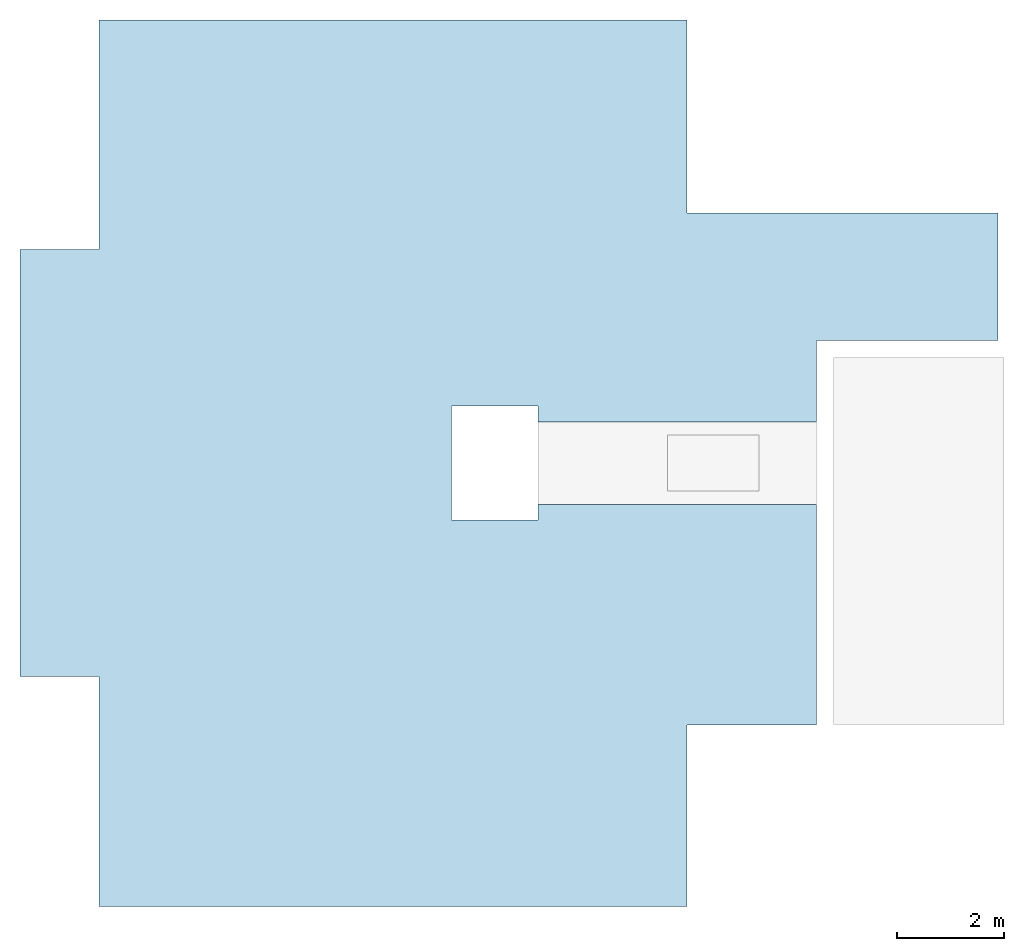
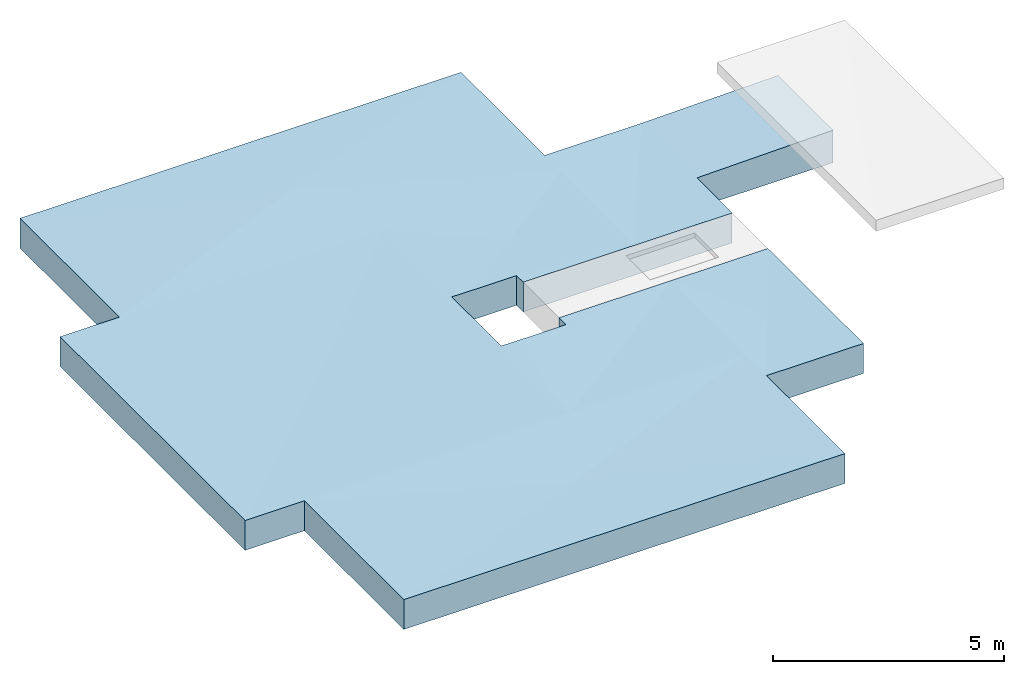
# One storey, part 2 of 2: 1 slab.
"""IFC2X3 building model written with IfcOpenShell, lengths in millimetres."""

from ifc_helpers import new_model, entity, si_unit, converted_unit, derived_unit, direction, frame, origin, place, context, subcontext, project, spatial, faceted_brep, material, material_list, type_object, element, save


model = new_model("IFC2X3")

# Units and contexts
model_context = context("Model", 3, precision=0.01, world=origin(), true_north=direction((6.12303176911189e-17, 1.0)))
body_context = subcontext(model_context, "Body", "Model", "MODEL_VIEW")
ifc_project = project(units=[si_unit("LENGTHUNIT", "METRE", prefix="MILLI"), si_unit("AREAUNIT", "SQUARE_METRE"), si_unit("VOLUMEUNIT", "CUBIC_METRE"), converted_unit("PLANEANGLEUNIT", "DEGREE", entity("IfcRatioMeasure", 0.0174532925199433), si_unit("PLANEANGLEUNIT", "RADIAN"), dimensions=[0, 0, 0, 0, 0, 0, 0]), si_unit("MASSUNIT", "GRAM", prefix="KILO"), derived_unit("MASSDENSITYUNIT", [(si_unit("MASSUNIT", "GRAM", prefix="KILO"), 1), (si_unit("LENGTHUNIT", "METRE"), -3)]), si_unit("TIMEUNIT", "SECOND"), si_unit("FREQUENCYUNIT", "HERTZ"), si_unit("THERMODYNAMICTEMPERATUREUNIT", "DEGREE_CELSIUS"), derived_unit("THERMALTRANSMITTANCEUNIT", [(si_unit("MASSUNIT", "GRAM", prefix="KILO"), 1), (si_unit("THERMODYNAMICTEMPERATUREUNIT", "KELVIN"), -1), (si_unit("TIMEUNIT", "SECOND"), -3)]), derived_unit("VOLUMETRICFLOWRATEUNIT", [(si_unit("LENGTHUNIT", "METRE"), 3), (si_unit("TIMEUNIT", "SECOND"), -1)]), si_unit("ELECTRICCURRENTUNIT", "AMPERE"), si_unit("ELECTRICVOLTAGEUNIT", "VOLT"), si_unit("POWERUNIT", "WATT"), si_unit("FORCEUNIT", "NEWTON", prefix="KILO"), si_unit("ILLUMINANCEUNIT", "LUX"), si_unit("LUMINOUSFLUXUNIT", "LUMEN"), si_unit("LUMINOUSINTENSITYUNIT", "CANDELA"), derived_unit("USERDEFINED", [(si_unit("MASSUNIT", "GRAM", prefix="KILO"), -1), (si_unit("LENGTHUNIT", "METRE"), -2), (si_unit("TIMEUNIT", "SECOND"), 3), (si_unit("LUMINOUSFLUXUNIT", "LUMEN"), 1)]), derived_unit("LINEARVELOCITYUNIT", [(si_unit("LENGTHUNIT", "METRE"), 1), (si_unit("TIMEUNIT", "SECOND"), -1)]), si_unit("PRESSUREUNIT", "PASCAL"), derived_unit("USERDEFINED", [(si_unit("LENGTHUNIT", "METRE"), -2), (si_unit("MASSUNIT", "GRAM", prefix="KILO"), 1), (si_unit("TIMEUNIT", "SECOND"), -2)])], contexts=[model_context])

# Site, building, storey
site_placement = place(None, origin())
site = spatial("IfcSite", under=ifc_project, at=site_placement, CompositionType="ELEMENT")
building_placement = place(site_placement, origin())
building = spatial("IfcBuilding", under=site, at=building_placement, CompositionType="ELEMENT")
storey_placement = place(building_placement, frame((0.0, 0.0, 16000.0)))
storey = spatial("IfcBuildingStorey", under=building, at=storey_placement, Name="04 Roof", CompositionType="ELEMENT", Elevation=16000.0)

# Slab
ifc_material_1 = material()
ifc_material_2 = material(Name="01")
ifc_material_3 = material(Name="04_XPS PLUS 30 SF")
ifc_material_4 = material(Name="06_ APP")
ifc_material_5 = material(Name="02_Beton, C40/55")
ifc_material_list = material_list([ifc_material_1, ifc_material_2, ifc_material_3, ifc_material_4, ifc_material_5])
slab_type = type_object("IfcSlabType", Name="Floor", PredefinedType="FLOOR")
slab_placement = place(storey_placement, origin())
element("IfcSlab", 1, at=slab_placement, inside=storey, type_object=slab_type, material=ifc_material_list, Name="Floor", ObjectType="Floor", PredefinedType="FLOOR", context=body_context, shape_type="Brep", body=[
    faceted_brep([(28513.4900708518, -64135.8241905964, -140.0), (28813.4900708518, -64135.8241905964, -140.0), (28943.4900708518, -64135.8241905964, -140.0), (30943.4900708518, -64135.8241905964, -140.0), (34353.4900708518, -64135.8241905964, -140.0), (34353.4900708518, -64275.8241905964, -140.0), (34353.4900708518, -66525.8241905964, -140.0), (30943.4900708518, -66525.8241905964, -140.0), (30943.4900708518, -68056.2395851399, -140.0), (25713.4900708518, -68056.2395851399, -140.0), (25713.4900708518, -67761.2395851399, -140.0), (24093.4900708518, -67761.2395851399, -140.0), (24093.4900708518, -68071.2395851399, -140.0), (24093.4900708518, -69591.2395851399, -140.0), (24093.4900708518, -69901.2395851399, -140.0), (25713.4900708518, -69901.2395851399, -140.0), (25713.4900708518, -69606.2395851399, -140.0), (30943.4900708518, -69606.2395851399, -140.0), (30943.4900708518, -73750.8241905963, -140.0), (28943.4900708518, -73750.8241905963, -140.0), (28513.4900708518, -73750.8241905963, -140.0), (28513.4900708518, -75951.2395851399, -140.0), (28513.4900708518, -77011.2395851399, -140.0), (28513.4900708518, -77151.2395851399, -140.0), (17613.4900708518, -77151.2395851399, -140.0), (17473.4900708518, -77151.2395851399, -140.0), (17473.4900708518, -73271.2395851399, -140.0), (17473.4900708518, -72841.2395851399, -140.0), (16128.4900708518, -72841.2395851399, -140.0), (15988.4900708518, -72841.2395851399, -140.0), (15988.4900708518, -64961.2395851399, -140.0), (15988.4900708518, -64821.2395851399, -140.0), (17043.4900708518, -64821.2395851399, -140.0), (17173.4900708518, -64821.2395851399, -140.0), (17473.4900708518, -64821.2395851399, -140.0), (17473.4900708518, -60651.2395851399, -140.0), (17473.4900708518, -60511.2395851399, -140.0), (28373.4900708518, -60511.23958514, -140.0), (28513.4900708518, -60511.23958514, -140.0), (28513.4900708518, -64135.8241905964, 650.0), (28943.4900708518, -64135.8241905964, 650.0), (30943.4900708518, -64135.8241905964, 650.0), (34353.4900708518, -64135.8241905964, 720.0), (34353.4900708518, -64275.8241905964, 720.0), (34353.4900708518, -66525.8241905964, 720.0), (34213.4900708518, -66525.8241905964, 717.126099706746), (30943.4900708518, -66525.8241905964, 650.0), (30943.4900708518, -68056.2395851399, 650.0), (30943.4900708518, -73750.8241905963, 650.0), (28943.4900708518, -73750.8241905963, 650.0), (28513.4900708518, -73750.8241905963, 650.0), (28513.4900708518, -77011.2395851399, 650.0), (28513.4900708518, -77151.2395851399, 650.0), (17613.4900708518, -77151.2395851399, 650.0), (17473.4900708518, -77151.2395851399, 650.0), (17473.4900708518, -73271.2395851399, 650.0), (17473.4900708518, -72841.2395851399, 650.0), (16128.4900708518, -72841.2395851399, 650.0), (15988.4900708518, -72841.2395851399, 650.0), (15988.4900708518, -64961.2395851399, 650.0), (15988.4900708518, -64821.2395851399, 650.0), (17043.4900708518, -64821.2395851399, 650.0), (17473.4900708518, -64821.2395851399, 650.0), (17473.4900708518, -60651.2395851399, 650.0), (17473.4900708518, -60511.2395851399, 650.0), (28373.4900708518, -60511.23958514, 650.0), (28513.4900708518, -60511.23958514, 650.0), (25713.4900708518, -67761.2395851399, 645.0), (24496.5503490589, -67761.2395851399, 645.0), (24093.4900708518, -67761.2395851399, 650.0), (24093.4900708518, -68071.2395851399, 650.0), (24093.4900708518, -69591.2395851399, 650.0), (24093.4900708518, -69901.2395851399, 650.0), (24496.5503490589, -69901.2395851399, 645.0), (25713.4900708518, -69901.2395851399, 645.0), (25713.4900708518, -68056.2395851399, 650.0), (28513.4900708518, -68056.2395851399, 650.0), (25713.4900708518, -69606.2395851399, 650.0), (28513.4900708518, -69606.2395851399, 650.0), (30943.4900708518, -69606.2395851399, 650.0), (30943.4900708518, -73610.8241905963, 650.0), (17828.8004156794, -60651.2395851399, 657.724137931033), (22993.4900708518, -62686.2395851399, 770.0), (28158.1797260242, -60651.23958514, 657.724137931033), (28373.4900708518, -60566.4026286182, 653.043478260868), (30861.4070559334, -73610.8241905963, 645.265218503155), (29729.9576094043, -71681.0349074948, 580.0), (28595.7716136097, -73610.8241905963, 645.26521850315), (17613.4900708518, -77096.0717899391, 646.94226657163), (17828.7698120245, -77011.2395851399, 642.240351849956), (22967.7558051175, -74986.1929650933, 530.0), (17613.4900708518, -72895.8953822414, 646.94226657163), (16130.017812821, -64961.2395851399, 645.831791605635), (20062.9814180885, -68851.7482379033, 530.0), (24093.4900708518, -64821.2395851399, 650.0), (17613.4900708518, -64821.2395851399, 650.0), (30851.699082573, -64275.8241905964, 644.711630304926), (29728.4900708518, -65988.9472824118, 580.0), (17613.4900708518, -72841.2395851399, 650.0), (24093.4900708518, -72841.2395851399, 650.0), (16131.4729072498, -72701.2395851399, 645.788936849896), (16128.4900708518, -72704.1601950973, 645.876785942521), (17613.4900708518, -64767.0910344153, 653.043478260868), (26303.4900708518, -71223.7395851399, 580.0), (28154.8821822207, -77011.2395851399, 642.240351849956), (28513.4900708518, -73740.8241905963, 650.0), (28513.4900708518, -73610.8241905963, 650.0), (28513.4900708518, -72841.2395851399, 650.0), (28513.4900708518, -64821.23958514, 650.0), (28513.4900708518, -64275.8241905964, 650.0), (26303.4900708518, -66438.7395851399, 580.0), (28605.2810591306, -64275.8241905964, 644.711630304926)], [[[0, 1, 2, 3, 4, 5, 6, 7, 8, 9, 10, 11, 12, 13, 14, 15, 16, 17, 18, 19, 20, 21, 22, 23, 24, 25, 26, 27, 28, 29, 30, 31, 32, 33, 34, 35, 36, 37, 38]], [[4, 3, 2, 1, 0, 39, 40, 41, 42]], [[6, 5, 4, 42, 43, 44]], [[7, 6, 44, 45, 46]], [[8, 7, 46, 47]], [[20, 19, 18, 48, 49, 50]], [[23, 22, 21, 20, 50, 51, 52]], [[25, 24, 23, 52, 53, 54]], [[27, 26, 25, 54, 55, 56]], [[29, 28, 27, 56, 57, 58]], [[31, 30, 29, 58, 59, 60]], [[34, 33, 32, 31, 60, 61, 62]], [[36, 35, 34, 62, 63, 64]], [[38, 37, 36, 64, 65, 66]], [[0, 38, 66, 39]], [[11, 10, 67, 68, 69]], [[14, 13, 12, 11, 69, 70, 71, 72]], [[15, 14, 72, 73, 74]], [[10, 9, 75, 67]], [[9, 8, 47, 76, 75]], [[16, 15, 74, 77]], [[17, 16, 77, 78, 79]], [[18, 17, 79, 80, 48]], [[66, 65, 64, 81, 82, 83, 84]], [[50, 49, 48, 85, 86, 87]], [[56, 55, 54, 88, 89, 90, 91]], [[77, 74, 78]], [[62, 61, 60, 92, 93, 94, 95]], [[47, 46, 41, 96, 97]], [[46, 45, 44, 43, 42, 41]], [[58, 57, 56, 98, 99, 93, 100, 101]], [[60, 59, 58, 101, 100, 93, 92]], [[72, 71, 70, 69, 94, 93, 99]], [[64, 63, 62, 102, 82, 81]], [[99, 103, 73]], [[48, 80, 79, 86, 85]], [[54, 53, 52, 104, 90, 89, 88]], [[52, 51, 50, 105, 106, 107, 90, 104]], [[67, 75, 76]], [[62, 95, 94, 108, 82, 102]], [[66, 84, 83, 82, 108, 109, 39]], [[56, 91, 90, 107, 99, 98]], [[79, 78, 86]], [[99, 107, 103]], [[103, 107, 78]], [[72, 99, 73]], [[74, 73, 103]], [[94, 110, 108]], [[110, 76, 108]], [[47, 97, 76]], [[39, 109, 108, 76, 97, 111]], [[50, 87, 86, 78, 107, 106, 105]], [[69, 68, 94]], [[74, 103, 78]], [[94, 68, 110]], [[67, 110, 68]], [[67, 76, 110]], [[39, 111, 97, 96, 41, 40]]]),
])

save(model, "model.ifc")
